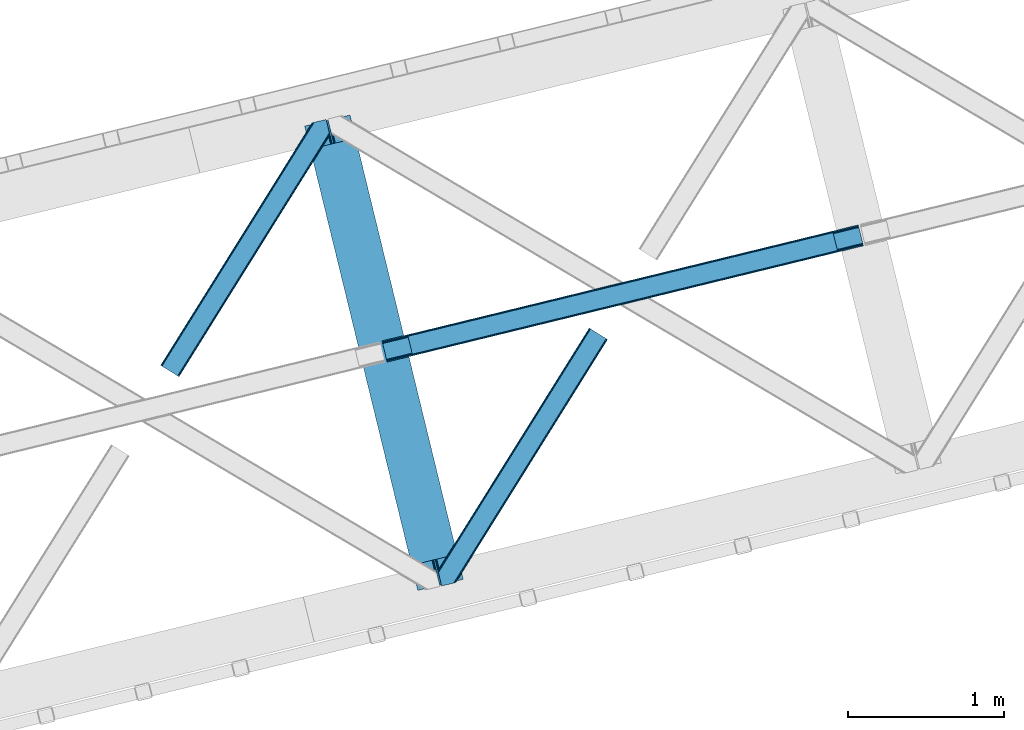
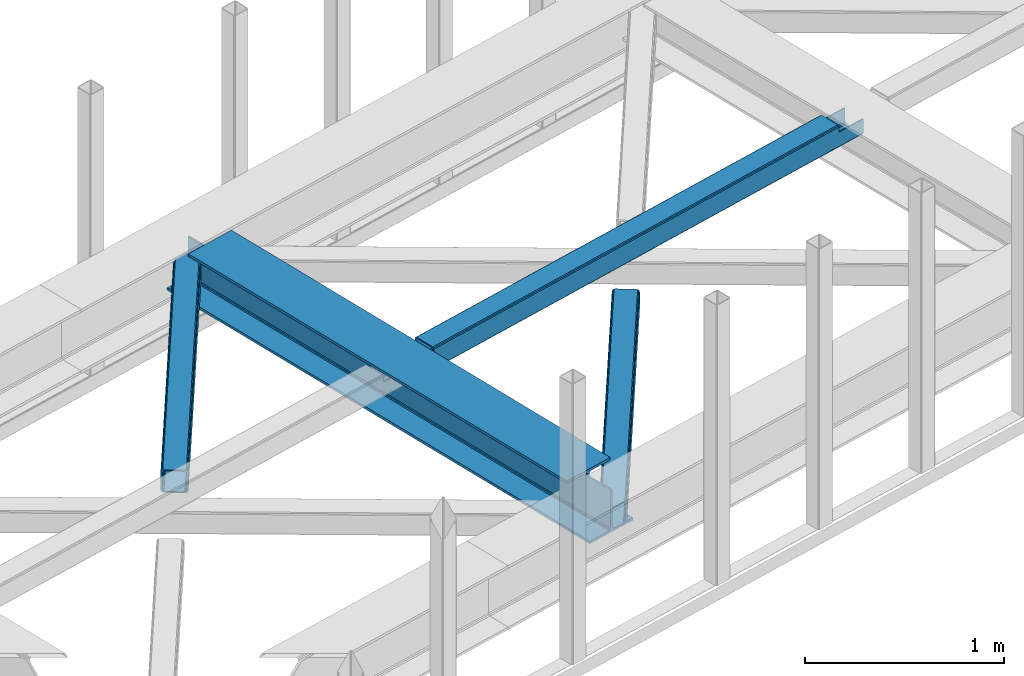
# One storey, part 44 of 66: 2 beams, 2 members.
"""IFC4 building model written with IfcOpenShell, lengths in millimetres."""

from ifc_helpers import new_model, entity, si_unit, converted_unit, derived_unit, direction, frame, origin, place, context, subcontext, project, spatial, triangles, polygons, material, type_object, element, save


model = new_model("IFC4")

# Units and contexts
model_context = context("Model", 3, precision=0.01, world=origin(), true_north=direction((6.12303176911189e-17, 1.0)))
plan_context = context("Plan", 3, precision=0.01, world=origin(), true_north=direction((6.12303176911189e-17, 1.0)))
body_context = subcontext(model_context, "Body", "Model", "MODEL_VIEW")
ifc_project = project(units=[si_unit("LENGTHUNIT", "METRE", prefix="MILLI"), si_unit("AREAUNIT", "SQUARE_METRE"), si_unit("VOLUMEUNIT", "CUBIC_METRE"), converted_unit("PLANEANGLEUNIT", "DEGREE", entity("IfcRatioMeasure", 0.0174532925199433), si_unit("PLANEANGLEUNIT", "RADIAN"), dimensions=[0, 0, 0, 0, 0, 0, 0]), si_unit("MASSUNIT", "GRAM", prefix="KILO"), derived_unit("MASSDENSITYUNIT", [(si_unit("MASSUNIT", "GRAM", prefix="KILO"), 1), (si_unit("LENGTHUNIT", "METRE"), -3)]), derived_unit("MOMENTOFINERTIAUNIT", [(si_unit("LENGTHUNIT", "METRE"), 4)]), si_unit("TIMEUNIT", "SECOND"), si_unit("FREQUENCYUNIT", "HERTZ"), si_unit("THERMODYNAMICTEMPERATUREUNIT", "DEGREE_CELSIUS"), derived_unit("THERMALTRANSMITTANCEUNIT", [(si_unit("MASSUNIT", "GRAM", prefix="KILO"), 1), (si_unit("THERMODYNAMICTEMPERATUREUNIT", "KELVIN"), -1), (si_unit("TIMEUNIT", "SECOND"), -3)]), derived_unit("VOLUMETRICFLOWRATEUNIT", [(si_unit("LENGTHUNIT", "METRE"), 3), (si_unit("TIMEUNIT", "SECOND"), -1)]), derived_unit("MASSFLOWRATEUNIT", [(si_unit("MASSUNIT", "GRAM", prefix="KILO"), 1), (si_unit("TIMEUNIT", "SECOND"), -1)]), derived_unit("ROTATIONALFREQUENCYUNIT", [(si_unit("TIMEUNIT", "SECOND"), -1)]), si_unit("ELECTRICCURRENTUNIT", "AMPERE"), si_unit("ELECTRICVOLTAGEUNIT", "VOLT"), si_unit("POWERUNIT", "WATT"), si_unit("FORCEUNIT", "NEWTON", prefix="KILO"), si_unit("ILLUMINANCEUNIT", "LUX"), si_unit("LUMINOUSFLUXUNIT", "LUMEN"), si_unit("LUMINOUSINTENSITYUNIT", "CANDELA"), derived_unit("USERDEFINED", [(si_unit("MASSUNIT", "GRAM", prefix="KILO"), -1), (si_unit("LENGTHUNIT", "METRE"), -2), (si_unit("TIMEUNIT", "SECOND"), 3), (si_unit("LUMINOUSFLUXUNIT", "LUMEN"), 1)]), derived_unit("LINEARVELOCITYUNIT", [(si_unit("LENGTHUNIT", "METRE"), 1), (si_unit("TIMEUNIT", "SECOND"), -1)]), si_unit("PRESSUREUNIT", "PASCAL"), derived_unit("USERDEFINED", [(si_unit("LENGTHUNIT", "METRE"), -2), (si_unit("MASSUNIT", "GRAM", prefix="KILO"), 1), (si_unit("TIMEUNIT", "SECOND"), -2)]), derived_unit("LINEARFORCEUNIT", [(si_unit("MASSUNIT", "GRAM", prefix="KILO"), 1), (si_unit("LENGTHUNIT", "METRE"), 1), (si_unit("TIMEUNIT", "SECOND"), -2), (si_unit("LENGTHUNIT", "METRE"), -1)]), derived_unit("PLANARFORCEUNIT", [(si_unit("MASSUNIT", "GRAM", prefix="KILO"), 1), (si_unit("LENGTHUNIT", "METRE"), 1), (si_unit("TIMEUNIT", "SECOND"), -2), (si_unit("LENGTHUNIT", "METRE"), -2)])], contexts=[model_context, plan_context])

# Site, building, storey
site_placement = place(None, origin())
site = spatial("IfcSite", under=ifc_project, at=site_placement, CompositionType="ELEMENT")
building_placement = place(site_placement, origin())
building = spatial("IfcBuilding", under=site, at=building_placement, CompositionType="ELEMENT")
storey_placement = place(building_placement, frame((0.0, 0.0, 19800.0)))
storey = spatial("IfcBuildingStorey", under=building, at=storey_placement, Name="06", CompositionType="ELEMENT", Elevation=19800.0)

# Beams
ifc_material = material(Name="Metal painted (White)")
beam_type = type_object("IfcBeamType", PredefinedType="BEAM")
beam_1_placement = place(storey_placement, frame((-21094.72, 12652.87, 3807.02)))
element("IfcBeam", 1, at=beam_1_placement, inside=storey, type_object=beam_type, material=ifc_material, ObjectType="Steel Beam", PredefinedType="BEAM", context=body_context, shape_type="Tessellation", body=[
    polygons([(1018.1664837833, 71.0478278971, 15.5000000000008), (1018.1664837833, 71.0478278971, 0.0), (291.465617442451, 3052.25531830422, 0.0), (291.465617442451, 3052.25531830421, 15.5000000000008), (894.779372399325, 40.970914087327, 15.5000000000008), (168.078506058478, 3022.17840449444, 15.5000000000008), (888.087028625379, 39.3395844888243, 16.8701684147984), (161.386162284533, 3020.54707489594, 16.8701684147984), (882.413533524764, 37.9566100336519, 20.7720779386434), (155.712667183908, 3019.16410044077, 20.7720779386434), (878.62262529618, 37.0325360459184, 26.6116982174294), (151.921758955329, 3018.24002645303, 26.6116982174294), (877.291435352788, 36.7080444135051, 33.5000000000054), (150.590569011941, 3017.91553482062, 33.5000000000054), (140.875048430527, 3015.54727389071, 33.500000000001), (140.875048430522, 3015.54727389071, 259.000000000002), (150.590569011941, 3017.91553482062, 259.000000000002), (8.66293703438714e-12, 2981.20749040711, 0.0), (4.33146851719357e-12, 2981.20749040711, 15.4999999999965), (123.387111383985, 3011.28440421689, 15.5000000000008), (130.079455157931, 3012.91573381539, 16.8701684147941), (135.752950258555, 3014.29870827056, 20.7720779386434), (139.543858487126, 3015.2227822583, 26.6116982174294), (877.291435352788, 36.7080444135051, 259.000000000002), (867.575914771373, 34.3397834835992, 259.000000000002), (867.575914771373, 34.3397834835992, 33.500000000001), (866.244724827977, 34.0152918511859, 26.6116982174294), (862.453816599402, 33.0912178634524, 20.7720779386434), (856.780321498777, 31.70824340828, 16.8701684147941), (850.087977724832, 30.0769138097752, 15.5000000000008), (726.700866340851, 2.16573425859679e-12, 15.4999999999965), (726.70086634086, 2.16573425859679e-12, 0.0), (838.124523615925, 197.385937999181, 259.069791973884), (186.46972209998, 2870.72539801218, 259.000000000002), (186.693115201833, 2869.80895360721, 259.617303331124), (186.705504045459, 2869.75812937344, 266.500003008253), (837.979344808156, 197.981416001704, 266.500002998871), (837.979694928912, 197.97997969697, 260.000004007589), (828.499586345876, 194.645865944432, 259.006343171919), (828.276216326115, 195.562317481911, 259.617303331124), (828.263827482481, 195.613141715687, 266.500003008253), (176.989986719788, 2867.38985508742, 266.500002998871), (176.989636599036, 2867.39129139215, 260.000004007589), (176.844830940692, 2867.98534020594, 259.07612046749), (176.754201518557, 2868.35713708228, 259.000000000002), (839.310832678079, 198.30468544639, 273.388305639783), (843.101109266775, 199.231350618306, 279.227924098781), (848.774180214305, 200.616065081981, 283.129832400619), (855.466371895434, 202.248018612794, 284.500000377224), (978.853400583278, 232.325271667903, 284.500000138971), (978.851730776626, 232.332121736637, 299.999995328161), (687.38630867936, 161.283492472596, 299.999995890962), (687.387978486003, 161.276642403863, 284.500000701776), (810.77500717386, 191.353895458976, 284.500000463519), (817.467494069995, 192.984637925553, 283.129832461069), (823.141405718764, 194.365903570081, 279.227924137322), (826.932940505747, 195.287407219375, 273.388305663684), (175.658498849865, 2867.06658564273, 273.388305639783), (171.868222261178, 2866.13992047082, 279.227924098781), (166.195151313635, 2864.75520600714, 283.129832400619), (159.50295963251, 2863.12325247633, 284.500000377228), (36.115930944662, 2833.04599942122, 284.500000138971), (36.1176007513137, 2833.03914935249, 299.999995328161), (327.583022848584, 2904.08777861653, 299.999995890962), (327.581353041937, 2904.09462868526, 284.500000701776), (204.194324354084, 2874.01737563015, 284.500000463519), (197.50183745795, 2872.38663316357, 283.129832461069), (191.827925809189, 2871.00536751905, 279.227924137322), (188.036391022193, 2870.08386386975, 273.388305663684)], [[[1, 2, 3, 4]], [[5, 1, 4, 6]], [[7, 5, 6, 8]], [[9, 7, 8, 10]], [[11, 9, 10, 12]], [[13, 11, 12, 14]], [[15, 16, 17, 14, 12, 10, 8, 6, 4, 3, 18, 19, 20, 21, 22, 23]], [[13, 24, 25, 26, 27, 28, 29, 30, 31, 32, 2, 1, 5, 7, 9, 11]], [[2, 32, 18, 3]], [[32, 31, 19, 18]], [[31, 30, 20, 19]], [[27, 26, 15, 23]], [[28, 27, 23, 22]], [[29, 28, 22, 21]], [[30, 29, 21, 20]], [[33, 24, 13, 14, 17, 34, 35, 36, 37, 38]], [[25, 39, 40, 41, 42, 43, 44, 16, 15, 26]], [[39, 25, 24, 33]], [[45, 34, 17, 16]], [[41, 40, 38, 37, 46, 47, 48, 49, 50, 51, 52, 53, 54, 55, 56, 57]], [[42, 58, 59, 60, 61, 62, 63, 64, 65, 66, 67, 68, 69, 36, 35, 43]], [[46, 37, 36, 69]], [[47, 46, 69, 68]], [[48, 47, 68, 67]], [[49, 48, 67, 66]], [[50, 49, 66, 65]], [[51, 50, 65, 64]], [[52, 51, 64, 63]], [[53, 52, 63, 62]], [[54, 53, 62, 61]], [[55, 54, 61, 60]], [[56, 55, 60, 59]], [[57, 56, 59, 58]], [[41, 57, 58, 42]]], closed=False),
])
beam_2_placement = place(storey_placement, frame((-20597.98, 14118.97, 3967.02)))
element("IfcBeam", 2, at=beam_2_placement, inside=storey, type_object=beam_type, material=ifc_material, ObjectType="Steel Beam", PredefinedType="BEAM", context=body_context, shape_type="Tessellation", body=[
    polygons([(31.1823923917744, 8.09507685195891, 17.8030399336114), (31.4978703677317, 6.80086440699434, 24.4999999999988), (3089.94374939708, 752.32940514057, 24.4999999999988), (3089.62827142112, 753.623617585539, 17.8030399336114), (30.2839871259208, 11.7806820741864, 12.1256313292298), (3088.72986615526, 757.309222807767, 12.1256313292298), (28.9394286278364, 17.2965800886753, 8.33210818105214), (3087.38530765718, 762.825120822251, 8.33210818105214), (27.3534137404035, 23.8030254244661, 7.00000000000274), (3085.79929276975, 769.331566158044, 7.00000000000274), (4.21622439084993, 118.720708051131, 8.33210818105214), (5.80223927828289, 112.214262715343, 7.00000000000274), (3064.24811830763, 857.742803448919, 7.00000000000274), (3062.66210342019, 864.249248784709, 8.33210818105214), (2.87166589276557, 124.23660606562, 12.1256313292342), (3061.31754492211, 869.765146799198, 12.1256313292342), (1.97326062691193, 127.922211287848, 17.8030399336114), (3060.41913965626, 873.450752021424, 17.8030399336114), (1.65778265095034, 129.216423732819, 24.4999999999988), (3060.1036616803, 874.744964466399, 24.4999999999988), (33.1556530186647, 2.16573425859679e-12, 17.5000000000004), (33.1556530186604, 2.16573425859679e-12, 99.499999999999), (31.4978703677317, 6.80086440699001, 99.499999999999), (1.65778265094601, 129.216423732814, 99.499999999999), (1.29944055515807e-11, 136.017288139804, 99.499999999999), (2.16573425859679e-11, 136.017288139807, 17.5000000000004), (0.315477975978911, 134.723075694836, 10.803039933613), (1.21388324183255, 131.037470472612, 5.12563132923143), (2.55844173991691, 125.521572458124, 1.33210818105373), (4.14445662734987, 119.015127122331, 0.0), (29.0111963913365, 17.0021610174739, 0.0), (30.5972112787694, 10.4957156816853, 1.33210818105373), (31.9417697768538, 4.97981766719418, 5.12563132923576), (32.8401750427074, 1.29421244496891, 10.803039933613), (3058.44587902937, 881.545828873387, 17.5000000000004), (3058.44587902937, 881.545828873387, 99.499999999999), (3060.1036616803, 874.744964466399, 99.499999999999), (3089.94374939709, 752.32940514057, 99.499999999999), (3091.60153204802, 745.528540733578, 99.499999999999), (3091.60153204802, 745.528540733582, 17.5000000000004), (3091.28605407206, 746.822753178549, 10.803039933613), (3090.38764880621, 750.508358400774, 5.12563132923576), (3089.04309030813, 756.024256415266, 1.33210818105373), (3087.45707542069, 762.530701751054, 0.0), (3062.5903356567, 864.543667855911, 0.0), (3061.00432076927, 871.050113191704, 1.33210818105373), (3059.65976227119, 876.566011206193, 5.12563132923143), (3058.76135700534, 880.25161642842, 10.803039933613), (2925.75994180942, 712.30786554088, 115.5000123926), (2925.81630989429, 712.321604759494, 100.117303289864), (2926.7230036293, 712.542621518191, 99.499999999999), (194.718606580801, 46.5876811586714, 99.5063429816656), (195.631369831912, 46.8101414944987, 100.117301735448), (195.690168193631, 46.8244741223546, 115.5), (2928.38078628023, 705.741757111199, 99.499999999999), (2927.47422618798, 705.520772937689, 100.117303484932), (2927.41464342031, 705.506249905349, 122.500007895425), (197.345360928052, 40.0229783796023, 122.500002534479), (197.338587096736, 40.0213271441479, 100.500009163303), (196.748205195729, 39.8773799905065, 99.5697919021647), (2896.88292546721, 834.958147714709, 99.5063429816656), (2895.97381660774, 834.736577551993, 100.117299778624), (2895.91744852287, 834.722838333379, 115.50000888136), (165.85008047685, 169.240033448181, 115.5), (165.840462203338, 169.237688832039, 100.50000941238), (165.250325295046, 169.093836777331, 99.5761204674868), (2894.85332685228, 841.668448882876, 99.5697919021647), (163.220745767773, 175.80407176218, 99.499999999999), (164.13324493851, 176.026503182394, 100.117301984524), (164.189439987628, 176.040201208961, 122.500002796667), (2894.25631754637, 841.522886341458, 122.500003994045), (2894.26642083519, 841.525349756024, 100.500018741102), (2894.56843170075, 840.227853719296, 129.196959150505), (2895.46176722634, 836.541012377602, 134.874360354937), (2896.8030582304, 831.024317672797, 138.667878733795), (2898.38810531641, 824.517636364722, 139.999985502214), (2923.25885436334, 722.505647815407, 139.999991354279), (2924.84634848092, 715.999563150007, 138.667885332354), (2926.19460804136, 710.484567539777, 134.874367586349), (2927.09837274857, 706.800269072825, 129.196966804773), (2925.44675217773, 713.602635936897, 122.196975799125), (2924.54298747051, 717.286934403852, 127.874376580702), (2923.19472791008, 722.801930014077, 131.667894326702), (2921.60723379249, 729.30801467948, 133.000000348631), (2900.05258461849, 817.718404755552, 132.999995276841), (2898.46753753248, 824.225086063627, 131.667888508414), (2897.12624652842, 829.741780768432, 127.874370129564), (2896.23291100283, 833.428622110126, 122.196968925133), (164.878528418706, 169.00320735519, 99.499999999999), (193.131726453736, 57.3201898040356, 131.667891818946), (191.545711566299, 63.8266351398307, 133.0), (194.476284951816, 51.8042917895488, 127.874368670764), (195.37469021767, 48.1186865673235, 122.196960066391), (169.994537104178, 152.237872430705, 133.0), (166.165558452807, 167.94582100321, 122.196960066391), (167.063963718661, 164.260215780987, 127.874368670764), (168.408522216745, 158.744317766498, 131.667891818946), (197.031411944069, 41.3175635421116, 129.196961104604), (196.136488323061, 45.0040174738959, 134.874366301861), (194.79424415731, 50.5204796458708, 138.667887185257), (193.209023953578, 57.0271186991972, 139.999994588639), (168.341882306932, 159.039986838386, 139.999994981919), (166.755021471185, 165.546225960032, 138.667887628704), (165.408105180726, 171.061549222925, 134.874366787843), (164.506189230956, 174.746298656822, 129.196961619)], [[[1, 2, 3, 4]], [[5, 1, 4, 6]], [[7, 5, 6, 8]], [[9, 7, 8, 10]], [[11, 12, 13, 14]], [[15, 11, 14, 16]], [[17, 15, 16, 18]], [[19, 17, 18, 20]], [[12, 9, 10, 13]], [[21, 22, 23, 2, 1, 5, 7, 9, 12, 11, 15, 17, 19, 24, 25, 26, 27, 28, 29, 30, 31, 32, 33, 34]], [[35, 36, 37, 20, 18, 16, 14, 13, 10, 8, 6, 4, 3, 38, 39, 40, 41, 42, 43, 44, 45, 46, 47, 48]], [[49, 50, 51, 38, 3, 2, 23, 52, 53, 54]], [[55, 39, 38, 51]], [[39, 55, 56, 57, 58, 59, 60, 22, 21, 40]], [[32, 31, 44, 43]], [[33, 32, 43, 42]], [[34, 33, 42, 41]], [[21, 34, 41, 40]], [[31, 30, 45, 44]], [[27, 26, 35, 48]], [[28, 27, 48, 47]], [[29, 28, 47, 46]], [[30, 29, 46, 45]], [[20, 37, 61, 62, 63, 64, 65, 66, 24, 19]], [[67, 36, 35, 26, 25, 68, 69, 70, 71, 72]], [[36, 67, 61, 37]], [[72, 71, 73, 74, 75, 76, 77, 78, 79, 80, 57, 56, 50, 49, 81, 82, 83, 84, 85, 86, 87, 88, 63, 62]], [[60, 52, 23, 22]], [[25, 24, 89, 68]], [[90, 91, 84, 83]], [[92, 90, 83, 82]], [[93, 92, 82, 81]], [[54, 93, 81, 49]], [[94, 85, 84, 91]], [[95, 64, 63, 88]], [[96, 95, 88, 87]], [[97, 96, 87, 86]], [[94, 97, 86, 85]], [[65, 64, 95, 96, 97, 94, 91, 90, 92, 93, 54, 53, 59, 58, 98, 99, 100, 101, 102, 103, 104, 105, 70, 69]], [[98, 58, 57, 80]], [[99, 98, 80, 79]], [[100, 99, 79, 78]], [[101, 100, 78, 77]], [[77, 76, 102, 101]], [[103, 102, 76, 75]], [[104, 103, 75, 74]], [[105, 104, 74, 73]], [[70, 105, 73, 71]]], closed=False),
])

# Members
member_type_1 = type_object("IfcMemberType", PredefinedType="BRACE")
member_1_placement = place(storey_placement, frame((-22019.95, 14024.23, 3823.0)))
element("IfcMember", 3, at=member_1_placement, inside=storey, type_object=member_type_1, ObjectType="Steel Horizontal Brace", PredefinedType="BRACE", context=body_context, shape_type="Tessellation", body=[
    triangles([(933.019793701169, 1535.69230957031, 0.0), (967.778137207031, 1393.09171142578, 0.0), (14.843280029294, 64.8692962646492, 0.0), (103.912261962891, 9.26687622070313, 0.0), (928.801446533202, 1552.99125366211, 5.49966430664063), (928.943298339844, 1552.41570739746, 5.208984375), (930.801324462889, 1544.78710327148, 1.33247680664135), (971.996484374999, 1375.79276733399, 5.49966430664063), (971.856958007811, 1376.36715087891, 5.208984375), (969.996606445311, 1383.99691772461, 1.33247680664135), (972.20577392578, 1375.53696899414, 5.8531311035149), (972.422039794921, 1375.28349609375, 6.20659790039281), (928.910742187498, 1553.56912536621, 5.74383544921875), (972.724346923827, 1375.53813171387, 6.35310058593677), (929.024688720703, 1554.17606506348, 5.9996337890625), (973.024328613279, 1375.79276733399, 6.49960327148438), (929.145611572265, 1554.78416748047, 6.25543212890625), (929.252581787106, 1555.36203918457, 6.49960327148438), (4.34624633788917, 71.4223846435561, 5.12526855468968), (1.12783813476563, 73.4304016113292, 10.8039916992202), (973.359191894531, 1630.84231567383, 10.8039916992202), (976.914788818358, 1631.70970458984, 6.49960327148438), (9.1622314453125, 68.4155914306648, 1.33247680664135), (971.505816650388, 1630.39118041992, 17.5012573242202), (0.0, 74.1361724853523, 17.5012573242202), (1081.09912719726, 1548.91708374024, 6.49960327148438), (1056.20762329101, 1651.03759460449, 6.49960327148438), (971.505816650388, 1630.39118041992, 122.499499511719), (0.0, 74.1361724853523, 122.499499511719), (973.359191894531, 1630.84231567383, 129.196765136719), (1.12783813476563, 73.4304016113292, 129.196765136719), (978.630963134765, 1632.12828369141, 134.87548828125), (4.34624633788917, 71.4223846435561, 134.87548828125), (986.525830078124, 1634.05258483887, 138.668280029298), (9.1622314453125, 68.4155914306648, 138.668280029298), (995.83921508789, 1636.32221374512, 140.00075683594), (14.843280029294, 64.8692962646492, 140.00075683594), (118.757867431639, 0.0, 17.5012573242202), (117.627703857419, 0.704608154297603, 10.8039916992202), (1085.1407409668, 1551.25066223145, 10.9783996582046), (1087.41502075195, 1552.56453552246, 13.4991760253906), (109.593310546872, 5.7205810546875, 1.33247680664135), (114.409295654295, 2.71378784179797, 5.12526855468968), (1087.56849975586, 1551.93550415039, 17.5012573242202), (1081.77583007812, 1575.70149536133, 140.00075683594), (1063.00720825195, 1652.69563293457, 140.00075683594), (103.912261962891, 9.26687622070313, 140.00075683594), (1083.99197387695, 1566.60670166016, 138.668280029298), (109.593310546872, 5.7205810546875, 138.668280029298), (1085.87092895508, 1558.89670715332, 134.87548828125), (114.409295654295, 2.71378784179797, 134.87548828125), (1087.12666625976, 1553.74469604492, 129.196765136719), (117.627703857419, 0.704608154297603, 129.196765136719), (1087.56849975586, 1551.93550415039, 122.499499511719), (118.757867431639, 0.0, 122.499499511719), (1082.53392333984, 1566.77297058106, 12.1248413085959), (1083.96406860351, 1566.72413635254, 13.4991760253906), (1077.85048828125, 1569.98556518555, 8.3320495605476), (1074.64370727539, 1577.50022277832, 6.99957275390625), (1056.69131469727, 1651.1561920166, 6.99957275390625), (1005.57117919922, 1638.69532470703, 6.99957275390625), (20.7824523925774, 61.1625457763676, 6.99957275390625), (97.9777404785127, 12.974789428712, 6.99957275390625), (108.474774169921, 6.42170104980505, 12.1248413085959), (111.693182373045, 4.41252136230469, 17.8035644531265), (1084.81052856445, 1563.2510925293, 17.8035644531265), (103.658789062498, 9.42733154296911, 8.3320495605476), (1085.25236206055, 1561.44190063477, 24.5008300781265), (112.82102050781, 3.70675048828161, 24.5008300781265), (983.091156005859, 1633.21542663574, 17.8035644531265), (981.24010620117, 1632.76429138184, 24.5008300781265), (7.06701049804542, 69.7248138427749, 17.8035644531265), (5.93917236327979, 70.430584716798, 24.5008300781265), (988.365252685544, 1634.50023193359, 12.1248413085959), (10.285418701169, 67.7156341552745, 12.1248413085959), (996.257794189452, 1636.42453308106, 8.3320495605476), (15.1014038085923, 64.7088409423832, 8.3320495605476), (981.24010620117, 1632.76429138184, 115.499926757813), (5.93917236327979, 70.430584716798, 115.499926757813), (996.257794189452, 1636.42453308106, 131.668707275392), (1005.57117919922, 1638.69532470703, 133.001184082033), (1063.00720825195, 1652.69563293457, 133.001184082033), (988.365252685544, 1634.50023193359, 127.873590087893), (983.091156005859, 1633.21542663574, 122.197192382813), (20.7824523925774, 61.1625457763676, 133.001184082033), (15.1014038085923, 64.7088409423832, 131.668707275392), (10.285418701169, 67.7156341552745, 127.873590087893), (7.06701049804542, 69.7248138427749, 122.197192382813), (108.474774169921, 6.42170104980505, 127.873590087893), (111.693182373045, 4.41252136230469, 122.197192382813), (112.82102050781, 3.70675048828161, 115.499926757813), (97.9777404785127, 12.974789428712, 133.001184082033), (103.658789062498, 9.42733154296911, 131.668707275392), (1085.25236206055, 1561.44190063477, 115.499926757813), (1084.81052856445, 1563.2510925293, 122.197192382813), (1083.55479125976, 1568.4031036377, 127.873590087893), (1081.67583618164, 1576.11309814453, 131.668707275392), (1079.45736694336, 1585.2078918457, 133.001184082033)], [[1, 2, 3], [4, 3, 2], [1, 5, 2], [6, 5, 1], [1, 7, 6], [2, 5, 8], [8, 9, 2], [10, 2, 9], [11, 8, 5], [12, 11, 13], [14, 12, 15], [16, 14, 17], [17, 18, 16], [15, 17, 14], [13, 15, 12], [5, 13, 11], [17, 19, 18], [19, 17, 15], [13, 19, 15], [19, 13, 5], [5, 6, 19], [20, 21, 18], [18, 19, 20], [21, 22, 18], [19, 6, 7], [7, 1, 23], [3, 23, 1], [7, 23, 19], [24, 21, 20], [20, 25, 24], [18, 26, 16], [26, 18, 22], [27, 26, 22], [28, 24, 25], [25, 29, 28], [30, 28, 31], [29, 31, 28], [32, 30, 33], [31, 33, 30], [34, 32, 35], [33, 35, 32], [36, 34, 37], [35, 37, 34], [38, 39, 40], [40, 41, 38], [42, 10, 9], [39, 12, 16], [16, 40, 39], [16, 26, 40], [9, 39, 43], [9, 12, 39], [9, 43, 42], [2, 10, 4], [42, 4, 10], [41, 44, 38], [45, 36, 37], [36, 45, 46], [37, 47, 45], [48, 45, 47], [47, 49, 48], [50, 48, 49], [49, 51, 50], [52, 50, 51], [51, 53, 52], [54, 52, 53], [53, 55, 54], [44, 54, 38], [55, 38, 54], [56, 40, 26], [41, 40, 56], [56, 57, 41], [58, 26, 59], [26, 58, 56], [60, 59, 26], [59, 61, 62], [61, 59, 60], [62, 63, 59], [64, 65, 66], [66, 57, 64], [58, 59, 63], [63, 67, 58], [56, 58, 67], [67, 64, 56], [57, 56, 64], [68, 66, 65], [65, 69, 68], [70, 71, 72], [73, 72, 71], [74, 70, 75], [72, 75, 70], [76, 74, 77], [75, 77, 74], [61, 76, 62], [77, 62, 76], [71, 78, 79], [79, 73, 71], [34, 36, 80], [46, 81, 36], [81, 46, 82], [81, 80, 36], [83, 34, 80], [83, 32, 34], [32, 84, 30], [84, 32, 83], [28, 84, 78], [84, 28, 30], [61, 22, 76], [70, 74, 22], [74, 76, 22], [61, 60, 22], [71, 70, 24], [21, 24, 70], [28, 71, 24], [71, 28, 78], [70, 22, 21], [80, 81, 85], [85, 86, 80], [83, 80, 86], [86, 87, 83], [84, 83, 87], [87, 88, 84], [78, 84, 88], [88, 79, 78], [53, 89, 90], [91, 38, 55], [53, 90, 55], [53, 51, 89], [90, 91, 55], [89, 51, 49], [92, 47, 37], [47, 93, 49], [93, 47, 92], [93, 89, 49], [39, 64, 43], [69, 38, 91], [38, 65, 39], [65, 38, 69], [39, 65, 64], [4, 63, 3], [42, 43, 64], [64, 67, 42], [67, 63, 4], [4, 42, 67], [87, 35, 33], [37, 85, 92], [37, 86, 85], [86, 37, 35], [87, 86, 35], [79, 29, 25], [31, 88, 87], [33, 31, 87], [88, 31, 29], [79, 88, 29], [23, 75, 19], [3, 63, 62], [62, 77, 3], [77, 75, 23], [23, 3, 77], [20, 19, 75], [25, 73, 79], [72, 25, 20], [25, 72, 73], [72, 20, 75], [66, 41, 57], [54, 44, 68], [44, 66, 68], [68, 94, 54], [44, 41, 66], [95, 54, 94], [52, 54, 95], [50, 95, 96], [95, 50, 52], [96, 48, 50], [97, 48, 96], [97, 98, 45], [97, 45, 48], [98, 46, 45], [98, 82, 46], [81, 98, 85], [81, 82, 98], [92, 85, 98], [95, 94, 90], [91, 90, 94], [96, 95, 89], [90, 89, 95], [97, 96, 93], [89, 93, 96], [98, 97, 92], [93, 92, 97], [94, 68, 91], [69, 91, 68]]),
])
member_type_2 = type_object("IfcMemberType", PredefinedType="BRACE")
member_2_placement = place(storey_placement, frame((-20238.88, 12681.07, 3823.0)))
element("IfcMember", 4, at=member_2_placement, inside=storey, type_object=member_type_2, ObjectType="Steel Horizontal Brace", PredefinedType="BRACE", context=body_context, shape_type="Tessellation", body=[
    triangles([(986.150271606446, 1647.42851257324, 0.0), (1075.22041625977, 1591.8260925293, 0.0), (119.788037109374, 259.603921508789, 0.0), (154.548706054688, 117.003323364257, 0.0), (115.902227783205, 275.544808959961, 4.52065429687718), (117.571893310549, 268.698715209961, 1.33247680664135), (158.434515380861, 101.062435913085, 4.52065429687718), (156.767175292971, 107.908529663086, 1.33247680664135), (114.825549316407, 275.742471313477, 5.52059326172093), (115.130181884768, 275.922692871094, 5.35316162109302), (158.132208251955, 99.1218566894531, 5.27642211914281), (115.439465332031, 276.107565307617, 5.18107910156323), (158.236853027345, 99.7776306152336, 5.02062377929906), (158.188018798828, 99.4811370849602, 5.13457031250073), (115.54178466797, 276.166864013672, 5.12526855468968), (115.685961914063, 275.921530151367, 4.88574829101708), (158.339172363281, 100.434567260741, 4.76482543945531), (158.032214355469, 98.4928253173821, 5.52059326172093), (1085.71628723145, 1585.27300415039, 5.12526855468968), (1080.90495300293, 1588.28096008301, 1.33247680664135), (1088.93469543457, 1583.26498718262, 10.8039916992202), (114.209307861329, 21.8521545410149, 10.8039916992202), (109.470062255859, 20.6964111328125, 5.52059326172093), (1090.0695098877, 1582.56037902832, 17.5012573242202), (116.062683105469, 22.3044525146488, 17.5012573242202), (6.7507507324226, 102.618154907226, 5.52059326172093), (31.3608764648452, 1.65687561035156, 5.52059326172093), (1090.0695098877, 1582.56037902832, 122.499499511719), (116.062683105469, 22.3044525146488, 122.499499511719), (1088.93469543457, 1583.26498718262, 129.196765136719), (114.209307861329, 21.8521545410149, 129.196765136719), (1085.71628723145, 1585.27300415039, 134.87548828125), (108.935211181641, 20.5673492431633, 134.87548828125), (1080.90495300293, 1588.28096008301, 138.668280029298), (101.042669677736, 18.6430480957024, 138.668280029298), (1075.22041625977, 1591.8260925293, 140.00075683594), (91.7292846679702, 16.3722564697255, 140.00075683594), (980.470385742188, 1650.97480773926, 1.33247680664135), (975.654400634765, 1653.98160095215, 5.12526855468968), (1.68826904297021, 100.410150146485, 10.9621215820334), (972.435992431641, 1655.99078063965, 10.8039916992202), (971.306991577148, 1656.69655151367, 17.5012573242202), (0.239520263672603, 99.7776306152336, 12.5201660156272), (0.0, 100.760128784179, 17.5012573242202), (5.79266967773583, 76.992974853516, 140.00075683594), (986.150271606446, 1647.42851257324, 140.00075683594), (24.5612915039055, 0.0, 140.00075683594), (971.306991577148, 1656.69655151367, 122.499499511719), (0.0, 100.760128784179, 122.499499511719), (980.470385742188, 1650.97480773926, 138.668280029298), (3.57652587890698, 86.088931274413, 138.668280029298), (975.654400634765, 1653.98160095215, 134.87548828125), (1.69524536133031, 93.7989257812496, 134.87548828125), (972.435992431641, 1655.99078063965, 129.196765136719), (0.439508056642808, 98.9509368896488, 129.196765136719), (29.9237548828132, 1.30689697265552, 6.99957275390625), (12.1969299316406, 74.0326904296871, 6.99957275390625), (8.99479980468823, 81.5485107421864, 8.3320495605476), (3.88813476562427, 84.8111022949215, 12.5201660156272), (1069.28589477539, 1595.53400573731, 6.99957275390625), (81.9973205566421, 14.000308227538, 6.99957275390625), (992.090606689453, 1643.72176208496, 6.99957275390625), (981.593572998048, 1650.27485046387, 12.1248413085959), (978.375164794921, 1652.28403015137, 17.8035644531265), (2.75797119140771, 89.4445404052731, 17.8035644531265), (986.409558105468, 1647.2692199707, 8.3320495605476), (977.246163940432, 1652.98980102539, 24.5008300781265), (2.31613769531396, 91.2537322998051, 24.5008300781265), (977.246163940432, 1652.98980102539, 115.499926757813), (2.31613769531396, 91.2537322998051, 115.499926757813), (4.01370849609521, 84.2925292968739, 127.873590087893), (2.75797119140771, 89.4445404052731, 122.197192382813), (5.89266357422093, 76.5813720703118, 131.668707275392), (8.11113281250073, 67.4865783691403, 133.001184082033), (24.5612915039055, 0.0, 133.001184082033), (978.375164794921, 1652.28403015137, 122.197192382813), (981.593572998048, 1650.27485046387, 127.873590087893), (986.409558105468, 1647.2692199707, 131.668707275392), (992.090606689453, 1643.72176208496, 133.001184082033), (1069.28589477539, 1595.53400573731, 133.001184082033), (81.9973205566421, 14.000308227538, 133.001184082033), (1079.78176574707, 1588.9809173584, 12.1248413085959), (1083.0001739502, 1586.9717376709, 17.8035644531265), (1084.12917480469, 1586.2671295166, 24.5008300781265), (1074.96578063965, 1591.98771057129, 8.3320495605476), (1079.78176574707, 1588.9809173584, 127.873590087893), (1084.12917480469, 1586.2671295166, 115.499926757813), (1083.0001739502, 1586.9717376709, 122.197192382813), (1074.96578063965, 1591.98771057129, 131.668707275392), (91.3083801269531, 16.2699371337894, 131.668707275392), (99.2032470703125, 18.1942382812504, 127.873590087893), (104.477343750001, 19.4802062988274, 122.197192382813), (106.32839355469, 19.931341552734, 115.499926757813), (91.3083801269531, 16.2699371337894, 8.3320495605476), (104.477343750001, 19.4802062988274, 17.8035644531265), (99.2032470703125, 18.1942382812504, 12.1248413085959), (106.32839355469, 19.931341552734, 24.5008300781265)], [[1, 2, 3], [4, 3, 2], [5, 3, 4], [3, 5, 6], [4, 7, 5], [7, 4, 8], [9, 10, 11], [10, 12, 13], [13, 14, 10], [12, 15, 16], [16, 17, 12], [16, 5, 7], [7, 17, 16], [17, 13, 12], [14, 11, 10], [11, 18, 9], [19, 14, 13], [13, 20, 19], [13, 17, 20], [17, 7, 20], [7, 8, 20], [21, 22, 18], [18, 19, 21], [14, 19, 11], [18, 11, 19], [22, 23, 18], [21, 24, 25], [25, 22, 21], [2, 20, 4], [8, 4, 20], [23, 26, 18], [23, 27, 26], [9, 18, 26], [24, 28, 29], [29, 25, 24], [28, 30, 29], [31, 29, 30], [30, 32, 31], [33, 31, 32], [32, 34, 33], [35, 33, 34], [34, 36, 35], [37, 35, 36], [38, 6, 5], [5, 39, 38], [5, 15, 39], [40, 41, 9], [41, 39, 15], [42, 41, 40], [40, 43, 42], [43, 44, 42], [9, 26, 40], [38, 1, 6], [3, 6, 1], [36, 45, 37], [36, 46, 45], [45, 47, 37], [48, 42, 44], [44, 49, 48], [46, 50, 51], [51, 45, 46], [50, 52, 53], [53, 51, 50], [52, 54, 55], [55, 53, 52], [54, 48, 49], [49, 55, 54], [27, 56, 57], [26, 57, 58], [57, 26, 27], [59, 40, 26], [26, 58, 59], [43, 40, 59], [60, 57, 61], [60, 62, 57], [57, 56, 61], [63, 64, 65], [65, 59, 63], [66, 63, 59], [62, 66, 58], [58, 57, 62], [59, 58, 66], [64, 67, 68], [68, 65, 64], [67, 69, 68], [70, 68, 69], [71, 53, 72], [73, 74, 45], [74, 47, 45], [74, 75, 47], [51, 73, 45], [71, 51, 53], [71, 73, 51], [49, 68, 70], [55, 72, 53], [70, 72, 49], [72, 55, 49], [44, 68, 49], [43, 59, 65], [65, 68, 44], [44, 43, 65], [69, 76, 70], [72, 70, 76], [76, 77, 72], [71, 72, 77], [77, 78, 71], [73, 71, 78], [78, 79, 73], [74, 73, 79], [80, 74, 79], [74, 80, 81], [75, 74, 81], [21, 82, 83], [84, 28, 24], [21, 83, 24], [21, 19, 82], [83, 84, 24], [82, 19, 20], [60, 2, 1], [2, 85, 20], [85, 2, 60], [85, 82, 20], [30, 86, 32], [87, 28, 84], [28, 88, 30], [88, 28, 87], [30, 88, 86], [36, 80, 46], [34, 32, 86], [86, 89, 34], [89, 80, 36], [36, 34, 89], [63, 38, 39], [1, 62, 60], [1, 66, 62], [66, 1, 38], [63, 66, 38], [67, 42, 48], [41, 64, 63], [39, 41, 63], [64, 41, 42], [67, 64, 42], [50, 77, 52], [46, 80, 79], [79, 78, 46], [78, 77, 50], [50, 46, 78], [54, 52, 77], [48, 69, 67], [76, 48, 54], [48, 76, 69], [76, 54, 77], [35, 37, 90], [47, 81, 37], [81, 47, 75], [81, 90, 37], [91, 35, 90], [91, 33, 35], [33, 92, 31], [92, 33, 91], [29, 92, 93], [92, 29, 31], [61, 23, 94], [95, 96, 23], [96, 94, 23], [61, 27, 23], [27, 61, 56], [97, 95, 25], [22, 25, 95], [29, 97, 25], [97, 29, 93], [95, 23, 22], [80, 89, 90], [90, 81, 80], [89, 86, 91], [91, 90, 89], [86, 88, 92], [92, 91, 86], [88, 87, 93], [93, 92, 88], [87, 84, 97], [97, 93, 87], [84, 83, 97], [95, 97, 83], [83, 82, 95], [96, 95, 82], [82, 85, 96], [94, 96, 85], [85, 60, 94], [61, 94, 60]]),
])

save(model, "model.ifc")
